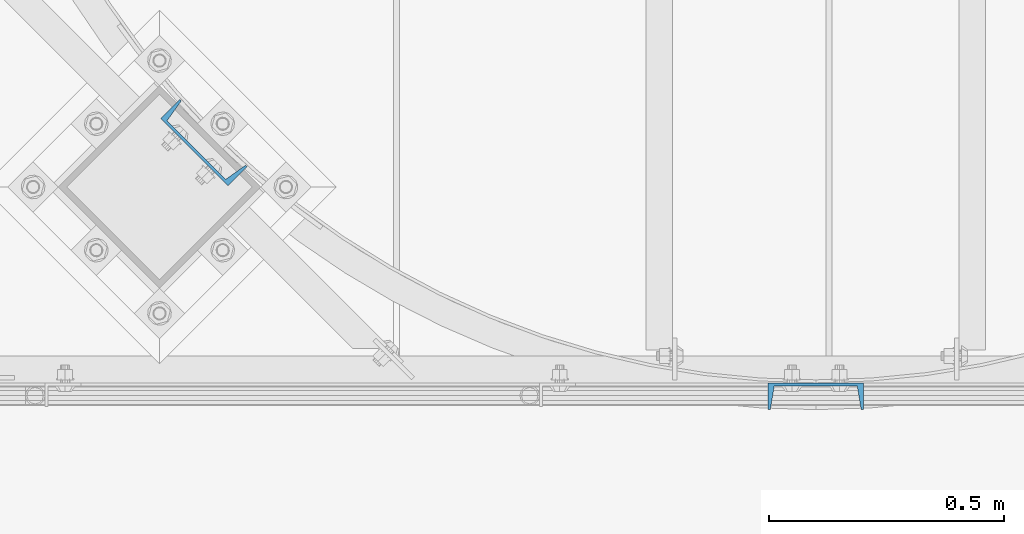
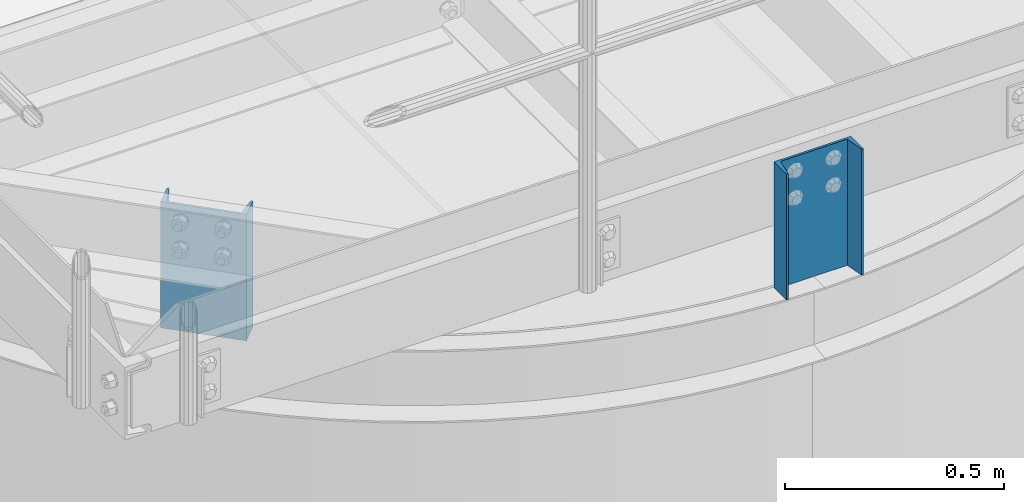
# One storey, part 780 of 1876: 2 columns, 2 elements without a shape of their own.
"""IFC2X3 building model written with IfcOpenShell, lengths in millimetres."""

from ifc_helpers import new_model, si_unit, frame, origin_with_axes, place, context, subcontext, project, spatial, faceted_brep, material, type_object, element, aggregate, save


model = new_model("IFC2X3")

# Units and contexts
model_context = context("Model", 3, precision=1e-05, world=origin_with_axes())
body_context = subcontext(model_context, "Body", "Model", "MODEL_VIEW")
ifc_project = project(units=[si_unit("LENGTHUNIT", "METRE", prefix="MILLI"), si_unit("AREAUNIT", "SQUARE_METRE"), si_unit("VOLUMEUNIT", "CUBIC_METRE"), si_unit("MASSUNIT", "GRAM", prefix="KILO"), si_unit("TIMEUNIT", "SECOND"), si_unit("PLANEANGLEUNIT", "RADIAN"), si_unit("SOLIDANGLEUNIT", "STERADIAN"), si_unit("THERMODYNAMICTEMPERATUREUNIT", "DEGREE_CELSIUS"), si_unit("LUMINOUSINTENSITYUNIT", "LUMEN")], contexts=[model_context])

# Site, building, storey
site_placement = place(None, origin_with_axes())
site = spatial("IfcSite", under=ifc_project, at=site_placement, CompositionType="ELEMENT")
building_placement = place(site_placement, origin_with_axes())
building = spatial("IfcBuilding", under=site, at=building_placement, Name="Undefined", CompositionType="ELEMENT")
storey_placement = place(building_placement, origin_with_axes())
storey = spatial("IfcBuildingStorey", under=building, at=storey_placement, Name="Undefined", CompositionType="ELEMENT", Elevation=0.0)

# Assembly, column
assembly_1_placement = place(storey_placement, origin_with_axes())
assembly_1 = element("IfcElementAssembly", 1, at=assembly_1_placement, inside=storey, Name="BEAM", AssemblyPlace="NOTDEFINED", PredefinedType="RIGID_FRAME")
ifc_material = material(Name="STEEL/A36")
column_type = type_object("IfcColumnType", Name="C8X11.5", PredefinedType="NOTDEFINED")
column_1_placement = place(assembly_1_placement, frame((5181.60140708713, -15433.7105468769, 7620.0), z_axis=(-1.0, 0.0, 0.0), x_axis=(0.0, 0.0, 1.0)))
column_1 = element("IfcColumn", 2, at=column_1_placement, type_object=column_type, material=ifc_material, Name="BEAM", ObjectType="C8X11.5", context=body_context, shape_type="Brep", body=[
    faceted_brep([(0.0, 28.5749999999998, -101.6), (0.0, 28.5749999999998, 101.6), (352.425, 28.5749999999998, 101.6), (352.425, 28.5749999999998, -101.6), (0.0, -28.5749999999998, 101.6), (352.425, -28.5749999999998, 101.6), (0.0, -28.5749999999998, 96.8355950000005), (352.425, -28.5749999999998, 96.8355950000005), (0.0, 22.2250000000004, 88.3723150000005), (352.425, 22.2250000000004, 88.3723150000005), (0.0, 22.2250000000004, -88.3723150000005), (352.425, 22.2250000000004, -88.3723150000005), (0.0, -28.5749999999998, -96.8355950000005), (352.425, -28.5749999999998, -96.8355950000005), (0.0, -28.5749999999998, -101.6), (352.425, -28.5749999999998, -101.6)], [[[0, 1, 2, 3]], [[1, 4, 5, 2]], [[4, 6, 7, 5]], [[6, 8, 9, 7]], [[8, 10, 11, 9]], [[10, 12, 13, 11]], [[12, 14, 15, 13]], [[14, 0, 3, 15]], [[5, 7, 9, 11, 13, 15, 3, 2]], [[14, 12, 10, 8, 6, 4, 1, 0]]]),
])
aggregate(assembly_1, [column_1])

assembly_2_placement = place(storey_placement, origin_with_axes())
assembly_2 = element("IfcElementAssembly", 3, at=assembly_2_placement, inside=storey, Name="BEAM", AssemblyPlace="NOTDEFINED", PredefinedType="RIGID_FRAME")
column_2_placement = place(assembly_2_placement, frame((3877.23669477364, -14893.3291410244, 7620.01566278096), z_axis=(0.707106781186547, -0.707106781186548, 0.0), x_axis=(0.0, 0.0, 1.0)))
column_2 = element("IfcColumn", 4, at=column_2_placement, type_object=column_type, material=ifc_material, Name="BEAM", ObjectType="C8X11.5", context=body_context, shape_type="Brep", body=[
    faceted_brep([(0.0, 28.5749999999998, -101.6), (0.0, 28.5749999999998, 101.6), (352.425, 28.5749999999998, 101.6), (352.425, 28.5749999999998, -101.6), (0.0, -28.5749999999998, 101.6), (352.425, -28.5749999999998, 101.6), (0.0, -28.5749999999998, 96.8355950000005), (352.425, -28.5749999999998, 96.8355950000005), (0.0, 22.2250000000004, 88.3723150000005), (352.425, 22.2250000000004, 88.3723150000005), (0.0, 22.2250000000004, -88.3723150000005), (352.425, 22.2250000000004, -88.3723150000005), (0.0, -28.5749999999998, -96.8355950000005), (352.425, -28.5749999999998, -96.8355950000005), (0.0, -28.5749999999998, -101.6), (352.425, -28.5749999999998, -101.6)], [[[0, 1, 2, 3]], [[1, 4, 5, 2]], [[4, 6, 7, 5]], [[6, 8, 9, 7]], [[8, 10, 11, 9]], [[10, 12, 13, 11]], [[12, 14, 15, 13]], [[14, 0, 3, 15]], [[5, 7, 9, 11, 13, 15, 3, 2]], [[14, 12, 10, 8, 6, 4, 1, 0]]]),
])
aggregate(assembly_2, [column_2])

save(model, "model.ifc")
